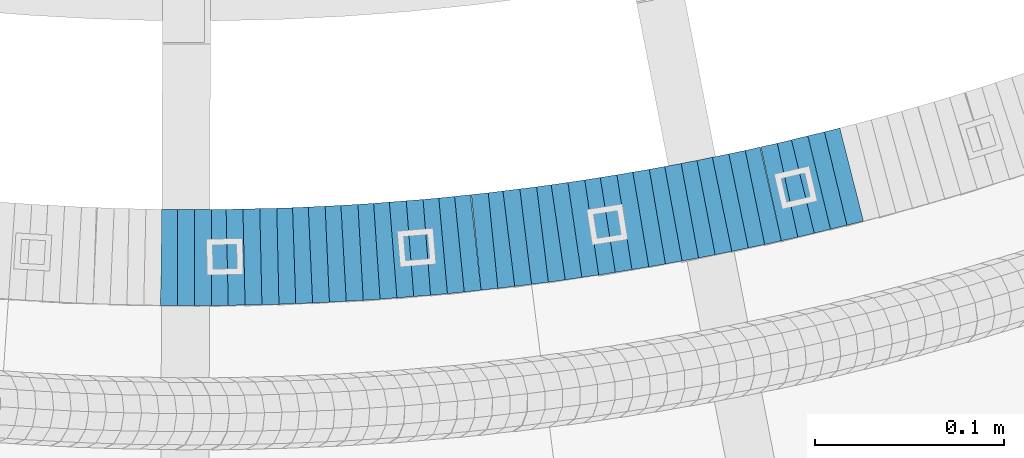
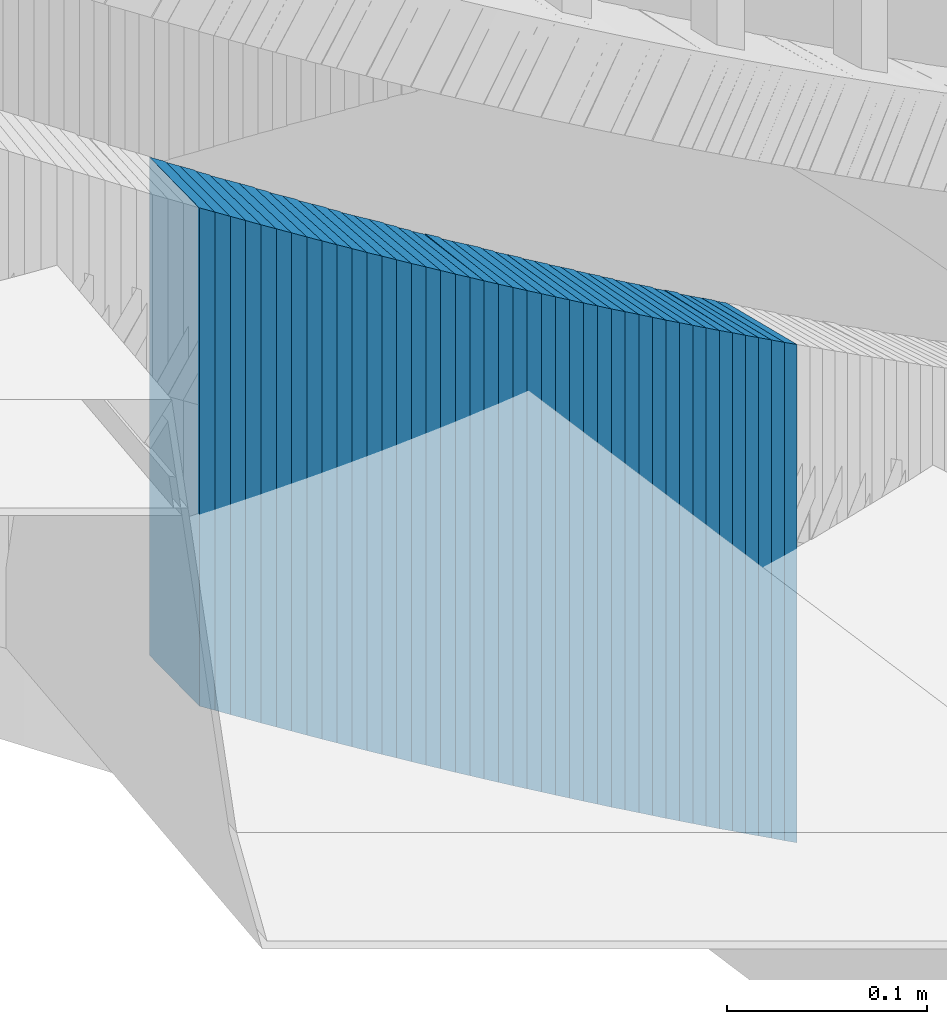
# One storey, part 881 of 975: 42 plates.
"""IFC2X3 building model written with IfcOpenShell, lengths in millimetres."""

from ifc_helpers import new_model, si_unit, frame, origin_with_axes, place, context, subcontext, project, spatial, faceted_brep, material, type_object, element, save


model = new_model("IFC2X3")

# Units and contexts
model_context = context("Model", 3, precision=1e-05, world=origin_with_axes())
body_context = subcontext(model_context, "Body", "Model", "MODEL_VIEW")
ifc_project = project(units=[si_unit("LENGTHUNIT", "METRE", prefix="MILLI"), si_unit("AREAUNIT", "SQUARE_METRE"), si_unit("VOLUMEUNIT", "CUBIC_METRE"), si_unit("MASSUNIT", "GRAM", prefix="KILO"), si_unit("TIMEUNIT", "SECOND"), si_unit("PLANEANGLEUNIT", "RADIAN"), si_unit("SOLIDANGLEUNIT", "STERADIAN"), si_unit("THERMODYNAMICTEMPERATUREUNIT", "DEGREE_CELSIUS"), si_unit("LUMINOUSINTENSITYUNIT", "LUMEN")], contexts=[model_context])

# Site, building, storey
site_placement = place(None, origin_with_axes())
site = spatial("IfcSite", under=ifc_project, at=site_placement, CompositionType="ELEMENT")
building_placement = place(site_placement, origin_with_axes())
building = spatial("IfcBuilding", under=site, at=building_placement, Name="Undefined", CompositionType="ELEMENT")
storey_placement = place(building_placement, origin_with_axes())
storey = spatial("IfcBuildingStorey", under=building, at=storey_placement, Name="Undefined", CompositionType="ELEMENT", Elevation=0.0)

# Plates
ifc_material = material(Name="STEEL/A36")
plate_type = type_object("IfcPlateType", PredefinedType="NOTDEFINED")
plate_1_placement = place(storey_placement, frame((34725.7474357191, 2006.47236188382, 3076.32500005033), z_axis=(-0.999938277323275, 0.0111104250035919, 0.0), x_axis=(0.0, 0.0, 1.0)))
element("IfcPlate", 1, at=plate_1_placement, inside=storey, type_object=plate_type, material=ifc_material, Name="WALL", context=body_context, shape_type="Brep", body=[
    faceted_brep([(0.0, -25.3999999999724, -1.81898940354586e-11), (5.69999980926514, -25.3999999999978, 9.00277709959482), (5.69999980926514, 25.3999999999651, 9.00277709966031), (0.0, 25.3999999999869, 1.45519152283669e-11), (310.5, -25.3999999999978, 9.00277709959482), (310.5, 25.3999999999651, 9.00277709966031), (304.799987792969, -25.3999999999724, -1.81898940354586e-11), (304.799987792969, 25.3999999999869, 1.45519152283669e-11)], [[[0, 1, 2, 3]], [[1, 4, 5, 2]], [[4, 6, 7, 5]], [[6, 0, 3, 7]], [[5, 7, 3, 2]], [[6, 4, 1, 0]]]),
])
for number, where, z_axis, x_axis, name in (
    (2, (34734.365230924, 2006.47392963985, 3070.62500005033), (-0.999999999999998, 6.90000001668524e-08, 0.0), (0.0, 0.0, 1.0), "WALL"),
    (3, (34743.265230924, 2006.47392963989, 3064.92500005033), (-0.999999999999998, 6.90000001668524e-08, 0.0), (0.0, 0.0, 1.0), "WALL"),
):
    element("IfcPlate", number, at=place(storey_placement, frame(where, z_axis=z_axis, x_axis=x_axis)), inside=storey, type_object=plate_type, material=ifc_material, Name=name, context=body_context, shape_type="Brep", body=[
        faceted_brep([(0.0, -25.3999999999724, -1.81898940354586e-11), (5.69999980926514, -25.3999999999469, 8.90224647518698), (5.69999980926514, 25.399999999936, 8.90224647526338), (0.0, 25.3999999999869, 1.45519152283669e-11), (310.5, -25.3999999999469, 8.90224647518698), (310.5, 25.399999999936, 8.90224647526338), (304.799987792969, -25.3999999999724, -1.81898940354586e-11), (304.799987792969, 25.3999999999869, 1.45519152283669e-11)], [[[0, 1, 2, 3]], [[1, 4, 5, 2]], [[4, 6, 7, 5]], [[6, 0, 3, 7]], [[5, 7, 3, 2]], [[6, 4, 1, 0]]]),
    ])
plate_2_placement = place(storey_placement, frame((34751.9830261306, 2006.57236188404, 3059.12500005033), z_axis=(-0.999938277323275, -0.0111104250035919, 0.0), x_axis=(0.0, 0.0, 1.0)))
element("IfcPlate", 4, at=plate_2_placement, inside=storey, type_object=plate_type, material=ifc_material, Name="WALL", context=body_context, shape_type="Brep", body=[
    faceted_brep([(0.0, -25.3999999999724, -1.81898940354586e-11), (5.80000019073486, -25.3999999999978, 9.00055599211555), (5.80000019073486, 25.3999999999651, 9.00055599218103), (0.0, 25.3999999999869, 1.45519152283669e-11), (310.600006103516, -25.3999999999978, 9.00055599211555), (310.600006103516, 25.3999999999651, 9.00055599218103), (304.799987792969, -25.3999999999724, -1.81898940354586e-11), (304.799987792969, 25.3999999999869, 1.45519152283669e-11)], [[[0, 1, 2, 3]], [[1, 4, 5, 2]], [[4, 6, 7, 5]], [[6, 0, 3, 7]], [[5, 7, 3, 2]], [[6, 4, 1, 0]]]),
])
for number, where, z_axis, x_axis, name in (
    (5, (34760.5945884727, 2006.76751873656, 3053.42500005033), (-0.999747602222632, -0.0224662380050029, 0.0), (0.0, 0.0, 1.0), "WALL"),
    (6, (34769.4945884651, 2006.96751873668, 3047.72500005033), (-0.999747602222632, -0.0224662380050029, 0.0), (0.0, 0.0, 1.0), "WALL"),
):
    element("IfcPlate", number, at=place(storey_placement, frame(where, z_axis=z_axis, x_axis=x_axis)), inside=storey, type_object=plate_type, material=ifc_material, Name=name, context=body_context, shape_type="Brep", body=[
        faceted_brep([(0.0, -25.3999999999724, -1.81898940354586e-11), (5.69999980926514, -25.3999999999469, 8.90224647518698), (5.69999980926514, 25.399999999936, 8.90224647526338), (0.0, 25.3999999999869, 1.45519152283669e-11), (310.5, -25.3999999999469, 8.90224647518698), (310.5, 25.399999999936, 8.90224647526338), (304.799987792969, -25.3999999999724, -1.81898940354586e-11), (304.799987792969, 25.3999999999869, 1.45519152283669e-11)], [[[0, 1, 2, 3]], [[1, 4, 5, 2]], [[4, 6, 7, 5]], [[6, 0, 3, 7]], [[5, 7, 3, 2]], [[6, 4, 1, 0]]]),
    ])
plate_3_placement = place(storey_placement, frame((34778.500925795, 2007.16766035739, 3041.92500005033), z_axis=(-0.999753177838027, -0.0222167369964006, 0.0), x_axis=(0.0, 0.0, 1.0)))
element("IfcPlate", 7, at=plate_3_placement, inside=storey, type_object=plate_type, material=ifc_material, Name="WALL", context=body_context, shape_type="Brep", body=[
    faceted_brep([(0.0, -25.3999999999724, -1.81898940354586e-11), (5.80000019073486, -25.3999999999978, 9.00055599211555), (5.80000019073486, 25.3999999999651, 9.00055599218103), (0.0, 25.3999999999869, 1.45519152283669e-11), (310.600006103516, -25.3999999999978, 9.00055599211555), (310.600006103516, 25.3999999999651, 9.00055599218103), (304.799987792969, -25.3999999999724, -1.81898940354586e-11), (304.799987792969, 25.3999999999869, 1.45519152283669e-11)], [[[0, 1, 2, 3]], [[1, 4, 5, 2]], [[4, 6, 7, 5]], [[6, 0, 3, 7]], [[5, 7, 3, 2]], [[6, 4, 1, 0]]]),
])
for number, where, z_axis, x_axis, name in (
    (8, (34787.1095371131, 2007.45951192894, 3036.22500005033), (-0.999432373568723, -0.0336887319854625, 0.0), (0.0, 0.0, 1.0), "WALL"),
    (9, (34795.7248090773, 2007.84831511195, 3030.52500005033), (-0.998991554001901, -0.0448984970000855, 0.0), (0.0, 0.0, 1.0), "WALL"),
    (10, (34804.6248090729, 2008.2483151119, 3024.82500005033), (-0.998991554001901, -0.0448984970000855, 0.0), (0.0, 0.0, 1.0), "WALL"),
):
    element("IfcPlate", number, at=place(storey_placement, frame(where, z_axis=z_axis, x_axis=x_axis)), inside=storey, type_object=plate_type, material=ifc_material, Name=name, context=body_context, shape_type="Brep", body=[
        faceted_brep([(0.0, -25.3999999999724, -1.81898940354586e-11), (5.69999980926514, -25.4000000000269, 8.91066741947361), (5.69999980926514, 25.4000000000269, 8.91066741941904), (0.0, 25.3999999999869, 1.45519152283669e-11), (310.5, -25.4000000000269, 8.91066741947361), (310.5, 25.4000000000269, 8.91066741941904), (304.799987792969, -25.3999999999724, -1.81898940354586e-11), (304.799987792969, 25.3999999999869, 1.45519152283669e-11)], [[[0, 1, 2, 3]], [[1, 4, 5, 2]], [[4, 6, 7, 5]], [[6, 0, 3, 7]], [[5, 7, 3, 2]], [[6, 4, 1, 0]]]),
    ])
plate_4_placement = place(storey_placement, frame((34813.2405111688, 2008.73394095118, 3019.02500005033), z_axis=(-0.99842564215979, -0.0560913280089769, 0.0), x_axis=(0.0, 0.0, 1.0)))
element("IfcPlate", 11, at=plate_4_placement, inside=storey, type_object=plate_type, material=ifc_material, Name="WALL", context=body_context, shape_type="Brep", body=[
    faceted_brep([(0.0, -25.3999999999724, -1.81898940354586e-11), (5.80000019073486, -25.3999999999796, 8.91403388975959), (5.80000019073486, 25.3999999999432, 8.91403388980689), (0.0, 25.3999999999869, 1.45519152283669e-11), (310.600006103515, -25.3999999999796, 8.91403388975959), (310.600006103515, 25.3999999999432, 8.91403388980689), (304.799987792969, -25.3999999999724, -1.81898940354586e-11), (304.799987792969, 25.3999999999869, 1.45519152283669e-11)], [[[0, 1, 2, 3]], [[1, 4, 5, 2]], [[4, 6, 7, 5]], [[6, 0, 3, 7]], [[5, 7, 3, 2]], [[6, 4, 1, 0]]]),
])
plate_5_placement = place(storey_placement, frame((34822.2562923899, 2009.23482261104, 3013.32500005033), z_axis=(-0.998460353183874, -0.055470020010215, 0.0), x_axis=(0.0, 0.0, 1.0)))
element("IfcPlate", 12, at=plate_5_placement, inside=storey, type_object=plate_type, material=ifc_material, Name="WALL", context=body_context, shape_type="Brep", body=[
    faceted_brep([(0.0, -25.3999999999724, -1.81898940354586e-11), (5.69999980926514, -25.4000000000233, 9.01387786867781), (5.69999980926514, 25.400000000016, 9.01387786863415), (0.0, 25.3999999999869, 1.45519152283669e-11), (310.5, -25.4000000000233, 9.01387786867781), (310.5, 25.400000000016, 9.01387786863415), (304.799987792969, -25.3999999999724, -1.81898940354586e-11), (304.799987792969, 25.3999999999869, 1.45519152283669e-11)], [[[0, 1, 2, 3]], [[1, 4, 5, 2]], [[4, 6, 7, 5]], [[6, 0, 3, 7]], [[5, 7, 3, 2]], [[6, 4, 1, 0]]]),
])
plate_6_placement = place(storey_placement, frame((34830.8567493711, 2009.81640566127, 3007.62500005033), z_axis=(-0.99773527642945, -0.0672630520289518, 0.0), x_axis=(0.0, 0.0, 1.0)))
element("IfcPlate", 13, at=plate_6_placement, inside=storey, type_object=plate_type, material=ifc_material, Name="WALL", context=body_context, shape_type="Brep", body=[
    faceted_brep([(0.0, -25.3999999999724, -1.81898940354586e-11), (5.69999980926514, -25.4000000000269, 8.9196414947728), (5.69999980926514, 25.3999999999796, 8.91964149476189), (0.0, 25.3999999999869, 1.45519152283669e-11), (310.5, -25.4000000000269, 8.9196414947728), (310.5, 25.3999999999796, 8.91964149476189), (304.799987792969, -25.3999999999724, -1.81898940354586e-11), (304.799987792969, 25.3999999999869, 1.45519152283669e-11)], [[[0, 1, 2, 3]], [[1, 4, 5, 2]], [[4, 6, 7, 5]], [[6, 0, 3, 7]], [[5, 7, 3, 2]], [[6, 4, 1, 0]]]),
])
plate_7_placement = place(storey_placement, frame((34839.4736286974, 2010.49572895848, 3001.82500005033), z_axis=(-0.996921233007399, -0.0784095350005817, 0.0), x_axis=(0.0, 0.0, 1.0)))
element("IfcPlate", 14, at=plate_7_placement, inside=storey, type_object=plate_type, material=ifc_material, Name="WALL", context=body_context, shape_type="Brep", body=[
    faceted_brep([(0.0, -25.3999999999724, -1.81898940354586e-11), (5.80000019073486, -25.3999999999869, 8.93084526053281), (5.80000019073486, 25.3999999999833, 8.9308452607147), (0.0, 25.3999999999869, 1.45519152283669e-11), (310.600006103516, -25.3999999999869, 8.93084526053281), (310.600006103516, 25.3999999999833, 8.9308452607147), (304.799987792969, -25.3999999999724, -1.81898940354586e-11), (304.799987792969, 25.3999999999869, 1.45519152283669e-11)], [[[0, 1, 2, 3]], [[1, 4, 5, 2]], [[4, 6, 7, 5]], [[6, 0, 3, 7]], [[5, 7, 3, 2]], [[6, 4, 1, 0]]]),
])
for number, where, z_axis, x_axis, name in (
    (15, (34848.3736286912, 2011.19572895857, 2996.12500005033), (-0.996921233007399, -0.0784095350005817, 0.0), (0.0, 0.0, 1.0), "WALL"),
    (16, (34857.273628685, 2011.89572895869, 2990.42500005033), (-0.996921233007399, -0.0784095350005817, 0.0), (0.0, 0.0, 1.0), "WALL"),
):
    element("IfcPlate", number, at=place(storey_placement, frame(where, z_axis=z_axis, x_axis=x_axis)), inside=storey, type_object=plate_type, material=ifc_material, Name=name, context=body_context, shape_type="Brep", body=[
        faceted_brep([(0.0, -25.3999999999724, -1.81898940354586e-11), (5.69999980926514, -25.3999999999542, 8.93084526058738), (5.69999980926514, 25.3999999999178, 8.93084526067832), (0.0, 25.3999999999869, 1.45519152283669e-11), (310.5, -25.3999999999542, 8.93084526058738), (310.5, 25.3999999999178, 8.93084526067832), (304.799987792969, -25.3999999999724, -1.81898940354586e-11), (304.799987792969, 25.3999999999869, 1.45519152283669e-11)], [[[0, 1, 2, 3]], [[1, 4, 5, 2]], [[4, 6, 7, 5]], [[6, 0, 3, 7]], [[5, 7, 3, 2]], [[6, 4, 1, 0]]]),
    ])
plate_8_placement = place(storey_placement, frame((34865.8912529447, 2012.67193399628, 2984.62500005033), z_axis=(-0.995984423457655, -0.0895266900411377, 0.0), x_axis=(0.0, 0.0, 1.0)))
element("IfcPlate", 17, at=plate_8_placement, inside=storey, type_object=plate_type, material=ifc_material, Name="WALL", context=body_context, shape_type="Brep", body=[
    faceted_brep([(0.0, -25.3999999999724, -1.81898940354586e-11), (5.80000019073486, -25.4000000000087, 8.9375610351708), (5.80000019073486, 25.400000000016, 8.93756103512715), (0.0, 25.3999999999869, 1.45519152283669e-11), (310.600006103516, -25.4000000000087, 8.9375610351708), (310.600006103516, 25.400000000016, 8.93756103512715), (304.799987792969, -25.3999999999724, -1.81898940354586e-11), (304.799987792969, 25.3999999999869, 1.45519152283669e-11)], [[[0, 1, 2, 3]], [[1, 4, 5, 2]], [[4, 6, 7, 5]], [[6, 0, 3, 7]], [[5, 7, 3, 2]], [[6, 4, 1, 0]]]),
])
plate_9_placement = place(storey_placement, frame((34874.5097245976, 2013.54504729895, 2978.92500005033), z_axis=(-0.994925892068904, -0.100610483006968, 0.0), x_axis=(0.0, 0.0, 1.0)))
element("IfcPlate", 18, at=plate_9_placement, inside=storey, type_object=plate_type, material=ifc_material, Name="WALL", context=body_context, shape_type="Brep", body=[
    faceted_brep([(0.0, -25.3999999999724, -1.81898940354586e-11), (5.69999980926514, -25.3999999999869, 8.94930171964734), (5.69999980926514, 25.4000000000051, 8.94930171966917), (0.0, 25.3999999999869, 1.45519152283669e-11), (310.5, -25.3999999999869, 8.94930171964734), (310.5, 25.4000000000051, 8.94930171966917), (304.799987792969, -25.3999999999724, -1.81898940354586e-11), (304.799987792969, 25.3999999999869, 1.45519152283669e-11)], [[[0, 1, 2, 3]], [[1, 4, 5, 2]], [[4, 6, 7, 5]], [[6, 0, 3, 7]], [[5, 7, 3, 2]], [[6, 4, 1, 0]]]),
])
plate_10_placement = place(storey_placement, frame((34883.1291444685, 2014.51509866867, 2973.12500005033), z_axis=(-0.993746812135698, -0.111656945015247, 0.0), x_axis=(0.0, 0.0, 1.0)))
element("IfcPlate", 19, at=plate_10_placement, inside=storey, type_object=plate_type, material=ifc_material, Name="WALL", context=body_context, shape_type="Brep", body=[
    faceted_brep([(0.0, -25.3999999999724, -1.81898940354586e-11), (5.80000019073486, -25.3999999999105, 8.96270084375283), (5.80000019073486, 25.399999999936, 8.96270084385833), (0.0, 25.3999999999869, 1.45519152283669e-11), (310.600006103516, -25.3999999999105, 8.96270084375283), (310.600006103516, 25.399999999936, 8.96270084385833), (304.799987792969, -25.3999999999724, -1.81898940354586e-11), (304.799987792969, 25.3999999999869, 1.45519152283669e-11)], [[[0, 1, 2, 3]], [[1, 4, 5, 2]], [[4, 6, 7, 5]], [[6, 0, 3, 7]], [[5, 7, 3, 2]], [[6, 4, 1, 0]]]),
])
plate_11_placement = place(storey_placement, frame((34892.3097245978, 2015.44504729892, 2967.42500005033), z_axis=(-0.994925892068904, -0.100610483006968, 0.0), x_axis=(0.0, 0.0, 1.0)))
element("IfcPlate", 20, at=plate_11_placement, inside=storey, type_object=plate_type, material=ifc_material, Name="WALL", context=body_context, shape_type="Brep", body=[
    faceted_brep([(0.0, -25.3999999999724, -1.81898940354586e-11), (5.69999980926514, -25.3999999999869, 8.94930171964734), (5.69999980926514, 25.4000000000051, 8.94930171966917), (0.0, 25.3999999999869, 1.45519152283669e-11), (310.5, -25.3999999999869, 8.94930171964734), (310.5, 25.4000000000051, 8.94930171966917), (304.799987792969, -25.3999999999724, -1.81898940354586e-11), (304.799987792969, 25.3999999999869, 1.45519152283669e-11)], [[[0, 1, 2, 3]], [[1, 4, 5, 2]], [[4, 6, 7, 5]], [[6, 0, 3, 7]], [[5, 7, 3, 2]], [[6, 4, 1, 0]]]),
])
plate_12_placement = place(storey_placement, frame((34900.6496116928, 2016.48212111044, 2961.62500005033), z_axis=(-0.99244848307505, -0.122662172009276, 0.0), x_axis=(0.0, 0.0, 1.0)))
element("IfcPlate", 21, at=plate_12_placement, inside=storey, type_object=plate_type, material=ifc_material, Name="WALL", context=body_context, shape_type="Brep", body=[
    faceted_brep([(0.0, -25.3999999999724, -1.81898940354586e-11), (5.80000019073486, -25.4000000000087, 8.96939277650381), (5.80000019073486, 25.3999999999905, 8.969392776522), (0.0, 25.3999999999869, 1.45519152283669e-11), (310.600006103516, -25.4000000000087, 8.96939277650381), (310.600006103516, 25.3999999999905, 8.969392776522), (304.799987792969, -25.3999999999724, -1.81898940354586e-11), (304.799987792969, 25.3999999999869, 1.45519152283669e-11)], [[[0, 1, 2, 3]], [[1, 4, 5, 2]], [[4, 6, 7, 5]], [[6, 0, 3, 7]], [[5, 7, 3, 2]], [[6, 4, 1, 0]]]),
])
for number, where, z_axis, x_axis, name in (
    (22, (34909.5496116884, 2017.5821211106, 2955.92500005033), (-0.99244848307505, -0.122662172009276, 0.0), (0.0, 0.0, 1.0), "WALL"),
    (23, (34918.449611684, 2018.68212111069, 2950.22500005033), (-0.99244848307505, -0.122662172009276, 0.0), (0.0, 0.0, 1.0), "WALL"),
):
    element("IfcPlate", number, at=place(storey_placement, frame(where, z_axis=z_axis, x_axis=x_axis)), inside=storey, type_object=plate_type, material=ifc_material, Name=name, context=body_context, shape_type="Brep", body=[
        faceted_brep([(0.0, -25.3999999999724, -1.81898940354586e-11), (5.69999980926514, -25.4000000000124, 8.96939277650017), (5.69999980926514, 25.3999999999869, 8.96939277651836), (0.0, 25.3999999999869, 1.45519152283669e-11), (310.5, -25.4000000000124, 8.96939277650017), (310.5, 25.3999999999869, 8.96939277651836), (304.799987792969, -25.3999999999724, -1.81898940354586e-11), (304.799987792969, 25.3999999999869, 1.45519152283669e-11)], [[[0, 1, 2, 3]], [[1, 4, 5, 2]], [[4, 6, 7, 5]], [[6, 0, 3, 7]], [[5, 7, 3, 2]], [[6, 4, 1, 0]]]),
    ])
plate_13_placement = place(storey_placement, frame((34927.0712235241, 2019.84615072286, 2944.42500005033), z_axis=(-0.991032326071817, -0.133622336009683, 0.0), x_axis=(0.0, 0.0, 1.0)))
element("IfcPlate", 24, at=plate_13_placement, inside=storey, type_object=plate_type, material=ifc_material, Name="WALL", context=body_context, shape_type="Brep", body=[
    faceted_brep([(0.0, -25.3999999999724, -1.81898940354586e-11), (5.80000019073486, -25.3999999999432, 8.98109149925949), (5.80000019073486, 25.3999999999651, 8.98109149937954), (0.0, 25.3999999999869, 1.45519152283669e-11), (310.600006103516, -25.3999999999432, 8.98109149925949), (310.600006103516, 25.3999999999651, 8.98109149937954), (304.799987792969, -25.3999999999724, -1.81898940354586e-11), (304.799987792969, 25.3999999999869, 1.45519152283669e-11)], [[[0, 1, 2, 3]], [[1, 4, 5, 2]], [[4, 6, 7, 5]], [[6, 0, 3, 7]], [[5, 7, 3, 2]], [[6, 4, 1, 0]]]),
])
plate_14_placement = place(storey_placement, frame((34935.5532435184, 2021.10122853948, 2938.72500005033), z_axis=(-0.989263736178206, -0.146141234026326, 0.0), x_axis=(0.0, 0.0, 1.0)))
element("IfcPlate", 25, at=plate_14_placement, inside=storey, type_object=plate_type, material=ifc_material, Name="WALL", context=body_context, shape_type="Brep", body=[
    faceted_brep([(0.0, -25.3999999999724, -1.81898940354586e-11), (5.69999980926514, -25.3999999999469, 8.90224647518698), (5.69999980926514, 25.399999999936, 8.90224647526338), (0.0, 25.3999999999869, 1.45519152283669e-11), (310.5, -25.3999999999469, 8.90224647518698), (310.5, 25.399999999936, 8.90224647526338), (304.799987792969, -25.3999999999724, -1.81898940354586e-11), (304.799987792969, 25.3999999999869, 1.45519152283669e-11)], [[[0, 1, 2, 3]], [[1, 4, 5, 2]], [[4, 6, 7, 5]], [[6, 0, 3, 7]], [[5, 7, 3, 2]], [[6, 4, 1, 0]]]),
])
plate_15_placement = place(storey_placement, frame((34944.4940751353, 2022.40722659152, 2932.92500005033), z_axis=(-0.989499879967826, -0.1445336899953, 0.0), x_axis=(0.0, 0.0, 1.0)))
element("IfcPlate", 26, at=plate_15_placement, inside=storey, type_object=plate_type, material=ifc_material, Name="WALL", context=body_context, shape_type="Brep", body=[
    faceted_brep([(0.0, -25.3999999999724, -1.81898940354586e-11), (5.80000019073486, -25.4000000000815, 8.99388694768095), (5.80000019073486, 25.4000000000342, 8.99388694761365), (0.0, 25.3999999999869, 1.45519152283669e-11), (310.600006103516, -25.4000000000815, 8.99388694768095), (310.600006103516, 25.4000000000342, 8.99388694761365), (304.799987792969, -25.3999999999724, -1.81898940354586e-11), (304.799987792969, 25.3999999999869, 1.45519152283669e-11)], [[[0, 1, 2, 3]], [[1, 4, 5, 2]], [[4, 6, 7, 5]], [[6, 0, 3, 7]], [[5, 7, 3, 2]], [[6, 4, 1, 0]]]),
])
plate_16_placement = place(storey_placement, frame((34952.9745086173, 2023.75846942001, 2927.22500005033), z_axis=(-0.987580306285744, -0.157115049045458, 0.0), x_axis=(0.0, 0.0, 1.0)))
element("IfcPlate", 27, at=plate_16_placement, inside=storey, type_object=plate_type, material=ifc_material, Name="WALL", context=body_context, shape_type="Brep", body=[
    faceted_brep([(0.0, -25.3999999999724, -1.81898940354586e-11), (5.69999980926514, -25.4000000000269, 8.91066741947361), (5.69999980926514, 25.4000000000269, 8.91066741941904), (0.0, 25.3999999999869, 1.45519152283669e-11), (310.5, -25.4000000000269, 8.91066741947361), (310.5, 25.4000000000269, 8.91066741941904), (304.799987792969, -25.3999999999724, -1.81898940354586e-11), (304.799987792969, 25.3999999999869, 1.45519152283669e-11)], [[[0, 1, 2, 3]], [[1, 4, 5, 2]], [[4, 6, 7, 5]], [[6, 0, 3, 7]], [[5, 7, 3, 2]], [[6, 4, 1, 0]]]),
])
plate_17_placement = place(storey_placement, frame((34961.7745086191, 2025.15846942006, 2921.42500005033), z_axis=(-0.987580306285744, -0.157115049045458, 0.0), x_axis=(0.0, 0.0, 1.0)))
element("IfcPlate", 28, at=plate_17_placement, inside=storey, type_object=plate_type, material=ifc_material, Name="WALL", context=body_context, shape_type="Brep", body=[
    faceted_brep([(0.0, -25.3999999999724, -1.81898940354586e-11), (5.80000019073486, -25.3999999999796, 8.91403388975959), (5.80000019073486, 25.3999999999432, 8.91403388980689), (0.0, 25.3999999999869, 1.45519152283669e-11), (310.600006103515, -25.3999999999796, 8.91403388975959), (310.600006103515, 25.3999999999432, 8.91403388980689), (304.799987792969, -25.3999999999724, -1.81898940354586e-11), (304.799987792969, 25.3999999999869, 1.45519152283669e-11)], [[[0, 1, 2, 3]], [[1, 4, 5, 2]], [[4, 6, 7, 5]], [[6, 0, 3, 7]], [[5, 7, 3, 2]], [[6, 4, 1, 0]]]),
])
plate_18_placement = place(storey_placement, frame((34970.4438671447, 2026.62068768113, 2915.72500005033), z_axis=(-0.986092836244413, -0.166195422041193, 0.0), x_axis=(0.0, 0.0, 1.0)))
element("IfcPlate", 29, at=plate_18_placement, inside=storey, type_object=plate_type, material=ifc_material, Name="WALL", context=body_context, shape_type="Brep", body=[
    faceted_brep([(0.0, -25.3999999999724, -1.81898940354586e-11), (5.69999980926514, -25.3999999999901, 9.02718162541714), (5.69999980926514, 25.3999999999951, 9.02718162535166), (0.0, 25.3999999999869, 1.45519152283669e-11), (310.5, -25.3999999999901, 9.02718162541714), (310.5, 25.3999999999951, 9.02718162535166), (304.799987792969, -25.3999999999724, -1.81898940354586e-11), (304.799987792969, 25.3999999999869, 1.45519152283669e-11)], [[[0, 1, 2, 3]], [[1, 4, 5, 2]], [[4, 6, 7, 5]], [[6, 0, 3, 7]], [[5, 7, 3, 2]], [[6, 4, 1, 0]]]),
])
plate_19_placement = place(storey_placement, frame((34979.1972441288, 2028.11278522924, 2910.02500005033), z_axis=(-0.985781716087097, -0.168030974014846, 0.0), x_axis=(0.0, 0.0, 1.0)))
element("IfcPlate", 30, at=plate_19_placement, inside=storey, type_object=plate_type, material=ifc_material, Name="WALL", context=body_context, shape_type="Brep", body=[
    faceted_brep([(0.0, -25.3999999999724, -1.81898940354586e-11), (5.69999980926514, -25.3999999999542, 8.93084526058738), (5.69999980926514, 25.3999999999178, 8.93084526067832), (0.0, 25.3999999999869, 1.45519152283669e-11), (310.5, -25.3999999999542, 8.93084526058738), (310.5, 25.3999999999178, 8.93084526067832), (304.799987792969, -25.3999999999724, -1.81898940354586e-11), (304.799987792969, 25.3999999999869, 1.45519152283669e-11)], [[[0, 1, 2, 3]], [[1, 4, 5, 2]], [[4, 6, 7, 5]], [[6, 0, 3, 7]], [[5, 7, 3, 2]], [[6, 4, 1, 0]]]),
])
plate_20_placement = place(storey_placement, frame((34987.7215407412, 2029.66422535805, 2904.22500005033), z_axis=(-0.983869910131907, -0.178885438023983, 0.0), x_axis=(0.0, 0.0, 1.0)))
element("IfcPlate", 31, at=plate_20_placement, inside=storey, type_object=plate_type, material=ifc_material, Name="WALL", context=body_context, shape_type="Brep", body=[
    faceted_brep([(0.0, -25.3999999999724, -1.81898940354586e-11), (5.80000019073486, -25.4000000000087, 8.9375610351708), (5.80000019073486, 25.400000000016, 8.93756103512715), (0.0, 25.3999999999869, 1.45519152283669e-11), (310.600006103516, -25.4000000000087, 8.9375610351708), (310.600006103516, 25.400000000016, 8.93756103512715), (304.799987792969, -25.3999999999724, -1.81898940354586e-11), (304.799987792969, 25.3999999999869, 1.45519152283669e-11)], [[[0, 1, 2, 3]], [[1, 4, 5, 2]], [[4, 6, 7, 5]], [[6, 0, 3, 7]], [[5, 7, 3, 2]], [[6, 4, 1, 0]]]),
])
plate_21_placement = place(storey_placement, frame((34996.3710136386, 2031.25498582492, 2898.52500005033), z_axis=(-0.983506148975214, -0.180874693995442, 0.0), x_axis=(0.0, 0.0, 1.0)))
element("IfcPlate", 32, at=plate_21_placement, inside=storey, type_object=plate_type, material=ifc_material, Name="WALL", context=body_context, shape_type="Brep", body=[
    faceted_brep([(0.0, -25.3999999999724, -1.81898940354586e-11), (5.69999980926514, -25.4000000000015, 8.84816360473997), (5.69999980926514, 25.4000000000487, 8.8481636046854), (0.0, 25.3999999999869, 1.45519152283669e-11), (310.5, -25.4000000000015, 8.84816360473997), (310.5, 25.4000000000487, 8.8481636046854), (304.799987792969, -25.3999999999724, -1.81898940354586e-11), (304.799987792969, 25.3999999999869, 1.45519152283669e-11)], [[[0, 1, 2, 3]], [[1, 4, 5, 2]], [[4, 6, 7, 5]], [[6, 0, 3, 7]], [[5, 7, 3, 2]], [[6, 4, 1, 0]]]),
])
plate_22_placement = place(storey_placement, frame((35004.9474864794, 2032.9128417865, 2892.82500005033), z_axis=(-0.98184693485788, -0.189674975972545, 0.0), x_axis=(0.0, 0.0, 1.0)))
element("IfcPlate", 33, at=plate_22_placement, inside=storey, type_object=plate_type, material=ifc_material, Name="WALL", context=body_context, shape_type="Brep", body=[
    faceted_brep([(0.0, -25.3999999999724, -1.81898940354586e-11), (5.69999980926514, -25.3999999999105, 8.96270084374919), (5.69999980926514, 25.399999999936, 8.96270084385469), (0.0, 25.3999999999869, 1.45519152283669e-11), (310.5, -25.3999999999105, 8.96270084374919), (310.5, 25.399999999936, 8.96270084385469), (304.799987792969, -25.3999999999724, -1.81898940354586e-11), (304.799987792969, 25.3999999999869, 1.45519152283669e-11)], [[[0, 1, 2, 3]], [[1, 4, 5, 2]], [[4, 6, 7, 5]], [[6, 0, 3, 7]], [[5, 7, 3, 2]], [[6, 4, 1, 0]]]),
])
plate_23_placement = place(storey_placement, frame((35013.4751664696, 2034.65868892175, 2887.02500005033), z_axis=(-0.979714932300414, -0.200396236061448, 0.0), x_axis=(0.0, 0.0, 1.0)))
element("IfcPlate", 34, at=plate_23_placement, inside=storey, type_object=plate_type, material=ifc_material, Name="WALL", context=body_context, shape_type="Brep", body=[
    faceted_brep([(0.0, -25.3999999999724, -1.81898940354586e-11), (5.80000019073486, -25.3999999999432, 8.98109149925949), (5.80000019073486, 25.3999999999651, 8.98109149937954), (0.0, 25.3999999999869, 1.45519152283669e-11), (310.600006103516, -25.3999999999432, 8.98109149925949), (310.600006103516, 25.3999999999651, 8.98109149937954), (304.799987792969, -25.3999999999724, -1.81898940354586e-11), (304.799987792969, 25.3999999999869, 1.45519152283669e-11)], [[[0, 1, 2, 3]], [[1, 4, 5, 2]], [[4, 6, 7, 5]], [[6, 0, 3, 7]], [[5, 7, 3, 2]], [[6, 4, 1, 0]]]),
])
for number, where, z_axis, x_axis, name in (
    (35, (35022.1190485342, 2036.44714429766, 2881.32500005033), (-0.979260419534469, -0.202605603903684, 0.0), (0.0, 0.0, 1.0), "WALL"),
    (36, (35030.8190485421, 2038.24714429771, 2875.62500005033), (-0.979260419534469, -0.202605603903684, 0.0), (0.0, 0.0, 1.0), "WALL"),
):
    element("IfcPlate", number, at=place(storey_placement, frame(where, z_axis=z_axis, x_axis=x_axis)), inside=storey, type_object=plate_type, material=ifc_material, Name=name, context=body_context, shape_type="Brep", body=[
        faceted_brep([(0.0, -25.3999999999724, -1.81898940354586e-11), (5.69999980926514, -25.4000000000306, 8.88144111634756), (5.69999980926514, 25.4000000000378, 8.88144111629663), (0.0, 25.3999999999869, 1.45519152283669e-11), (310.5, -25.4000000000306, 8.88144111634756), (310.5, 25.4000000000378, 8.88144111629663), (304.799987792969, -25.3999999999724, -1.81898940354586e-11), (304.799987792969, 25.3999999999869, 1.45519152283669e-11)], [[[0, 1, 2, 3]], [[1, 4, 5, 2]], [[4, 6, 7, 5]], [[6, 0, 3, 7]], [[5, 7, 3, 2]], [[6, 4, 1, 0]]]),
    ])
plate_24_placement = place(storey_placement, frame((35039.136054843, 2040.1423041768, 2869.92500005033), z_axis=(-0.975132855712874, -0.221621103934745, 0.0), x_axis=(0.0, 0.0, 1.0)))
element("IfcPlate", 37, at=plate_24_placement, inside=storey, type_object=plate_type, material=ifc_material, Name="WALL", context=body_context, shape_type="Brep", body=[
    faceted_brep([(0.0, -25.3999999999724, -1.81898940354586e-11), (5.69999980926514, -25.4000000000087, 9.02108669283189), (5.69999980926514, 25.4000000000087, 9.02108669277368), (0.0, 25.3999999999869, 1.45519152283669e-11), (310.5, -25.4000000000087, 9.02108669283189), (310.5, 25.4000000000087, 9.02108669277368), (304.799987792969, -25.3999999999724, -1.81898940354586e-11), (304.799987792969, 25.3999999999869, 1.45519152283669e-11)], [[[0, 1, 2, 3]], [[1, 4, 5, 2]], [[4, 6, 7, 5]], [[6, 0, 3, 7]], [[5, 7, 3, 2]], [[6, 4, 1, 0]]]),
])
plate_25_placement = place(storey_placement, frame((35048.0458369213, 2042.08904940919, 2864.12500005033), z_axis=(-0.97697321919279, -0.213361967042104, 0.0), x_axis=(0.0, 0.0, 1.0)))
element("IfcPlate", 38, at=plate_25_placement, inside=storey, type_object=plate_type, material=ifc_material, Name="WALL", context=body_context, shape_type="Brep", body=[
    faceted_brep([(0.0, -25.3999999999724, -1.81898940354586e-11), (5.80000019073486, -25.3999999999796, 8.91403388975959), (5.80000019073486, 25.3999999999432, 8.91403388980689), (0.0, 25.3999999999869, 1.45519152283669e-11), (310.600006103515, -25.3999999999796, 8.91403388975959), (310.600006103515, 25.3999999999432, 8.91403388980689), (304.799987792969, -25.3999999999724, -1.81898940354586e-11), (304.799987792969, 25.3999999999869, 1.45519152283669e-11)], [[[0, 1, 2, 3]], [[1, 4, 5, 2]], [[4, 6, 7, 5]], [[6, 0, 3, 7]], [[5, 7, 3, 2]], [[6, 4, 1, 0]]]),
])
plate_26_placement = place(storey_placement, frame((35056.2053613474, 2044.06481774082, 2858.42500005033), z_axis=(-0.972082208620478, -0.234640532908391, 0.0), x_axis=(0.0, 0.0, 1.0)))
element("IfcPlate", 39, at=plate_26_placement, inside=storey, type_object=plate_type, material=ifc_material, Name="WALL", context=body_context, shape_type="Brep", body=[
    faceted_brep([(0.0, -25.3999999999724, -1.81898940354586e-11), (5.69999980926514, -25.3999999999869, 8.94930171964734), (5.69999980926514, 25.4000000000051, 8.94930171966917), (0.0, 25.3999999999869, 1.45519152283669e-11), (310.5, -25.3999999999869, 8.94930171964734), (310.5, 25.4000000000051, 8.94930171966917), (304.799987792969, -25.3999999999724, -1.81898940354586e-11), (304.799987792969, 25.3999999999869, 1.45519152283669e-11)], [[[0, 1, 2, 3]], [[1, 4, 5, 2]], [[4, 6, 7, 5]], [[6, 0, 3, 7]], [[5, 7, 3, 2]], [[6, 4, 1, 0]]]),
])
plate_27_placement = place(storey_placement, frame((35064.7399390288, 2046.1489343634, 2852.72500005033), z_axis=(-0.971456878798254, -0.237216214950736, 0.0), x_axis=(0.0, 0.0, 1.0)))
element("IfcPlate", 40, at=plate_27_placement, inside=storey, type_object=plate_type, material=ifc_material, Name="WALL", context=body_context, shape_type="Brep", body=[
    faceted_brep([(0.0, -25.3999999999724, -1.81898940354586e-11), (5.69999980926514, -25.4000000000015, 8.84816360473997), (5.69999980926514, 25.4000000000487, 8.8481636046854), (0.0, 25.3999999999869, 1.45519152283669e-11), (310.5, -25.4000000000015, 8.84816360473997), (310.5, 25.4000000000487, 8.8481636046854), (304.799987792969, -25.3999999999724, -1.81898940354586e-11), (304.799987792969, 25.3999999999869, 1.45519152283669e-11)], [[[0, 1, 2, 3]], [[1, 4, 5, 2]], [[4, 6, 7, 5]], [[6, 0, 3, 7]], [[5, 7, 3, 2]], [[6, 4, 1, 0]]]),
])
plate_28_placement = place(storey_placement, frame((35073.5053613518, 2048.264817741, 2846.92500005033), z_axis=(-0.972082208620478, -0.234640532908391, 0.0), x_axis=(0.0, 0.0, 1.0)))
element("IfcPlate", 41, at=plate_28_placement, inside=storey, type_object=plate_type, material=ifc_material, Name="WALL", context=body_context, shape_type="Brep", body=[
    faceted_brep([(0.0, -25.3999999999724, -1.81898940354586e-11), (5.80000019073486, -25.3999999999942, 8.94930171964734), (5.80000019073486, 25.4000000000015, 8.94930171966917), (0.0, 25.3999999999869, 1.45519152283669e-11), (310.600006103516, -25.3999999999942, 8.94930171964734), (310.600006103516, 25.4000000000015, 8.94930171966917), (304.799987792969, -25.3999999999724, -1.81898940354586e-11), (304.799987792969, 25.3999999999869, 1.45519152283669e-11)], [[[0, 1, 2, 3]], [[1, 4, 5, 2]], [[4, 6, 7, 5]], [[6, 0, 3, 7]], [[5, 7, 3, 2]], [[6, 4, 1, 0]]]),
])
plate_29_placement = place(storey_placement, frame((35081.9382497975, 2050.39880946869, 2841.22500005033), z_axis=(-0.969483457737362, -0.245156735933585, 0.0), x_axis=(0.0, 0.0, 1.0)))
element("IfcPlate", 42, at=plate_29_placement, inside=storey, type_object=plate_type, material=ifc_material, Name="WALL", context=body_context, shape_type="Brep", body=[
    faceted_brep([(0.0, -25.3999999999724, -1.81898940354586e-11), (5.69999980926514, -25.4000000000124, 8.96939277650017), (5.69999980926514, 25.3999999999869, 8.96939277651836), (0.0, 25.3999999999869, 1.45519152283669e-11), (310.5, -25.4000000000124, 8.96939277650017), (310.5, 25.3999999999869, 8.96939277651836), (304.799987792969, -25.3999999999724, -1.81898940354586e-11), (304.799987792969, 25.3999999999869, 1.45519152283669e-11)], [[[0, 1, 2, 3]], [[1, 4, 5, 2]], [[4, 6, 7, 5]], [[6, 0, 3, 7]], [[5, 7, 3, 2]], [[6, 4, 1, 0]]]),
])

save(model, "model.ifc")
